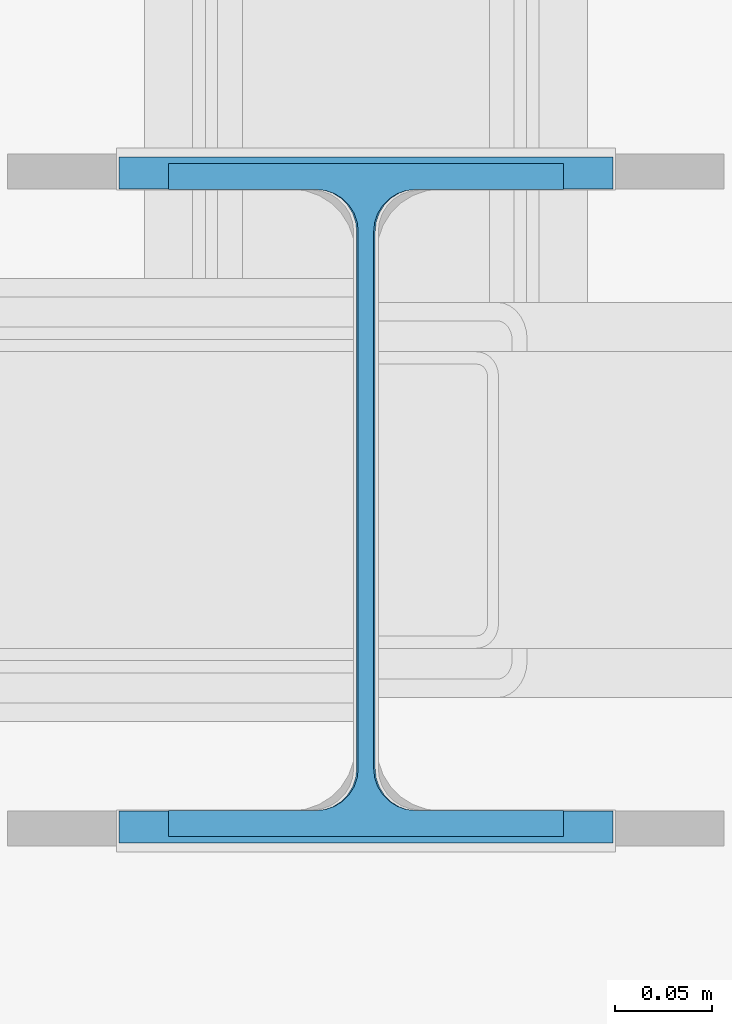
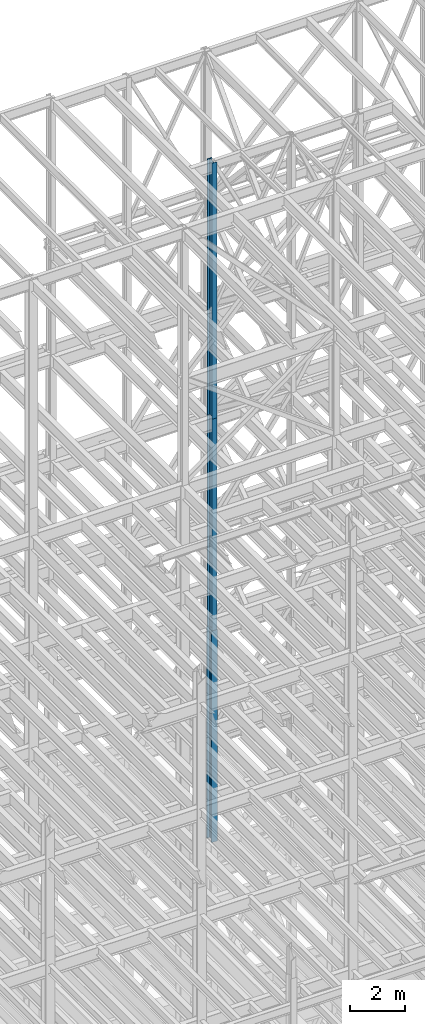
# One storey, part 40 of 150: 3 columns.
"""IFC2X3 building model written with IfcOpenShell, lengths in millimetres."""

from ifc_helpers import new_model, si_unit, frame, origin_with_axes, origin_2d_with_axis, place, context, subcontext, project, spatial, i_section, extrude, material, type_object, element, save


model = new_model("IFC2X3")

# Units and contexts
model_context = context("Model", 3, precision=1e-05, world=origin_with_axes())
body_context = subcontext(model_context, "Body", "Model", "MODEL_VIEW")
ifc_project = project(units=[si_unit("LENGTHUNIT", "METRE", prefix="MILLI"), si_unit("AREAUNIT", "SQUARE_METRE"), si_unit("VOLUMEUNIT", "CUBIC_METRE"), si_unit("MASSUNIT", "GRAM", prefix="KILO"), si_unit("TIMEUNIT", "SECOND"), si_unit("PLANEANGLEUNIT", "RADIAN"), si_unit("SOLIDANGLEUNIT", "STERADIAN"), si_unit("THERMODYNAMICTEMPERATUREUNIT", "DEGREE_CELSIUS"), si_unit("LUMINOUSINTENSITYUNIT", "LUMEN")], contexts=[model_context])

# Site, building, storey
site_placement = place(None, origin_with_axes())
site = spatial("IfcSite", under=ifc_project, at=site_placement, CompositionType="ELEMENT")
building_placement = place(site_placement, origin_with_axes())
building = spatial("IfcBuilding", under=site, at=building_placement, Name="Undefined", CompositionType="ELEMENT")
storey_placement = place(building_placement, origin_with_axes())
storey = spatial("IfcBuildingStorey", under=building, at=storey_placement, Name="Undefined", CompositionType="ELEMENT", Elevation=0.0)

# Columns
ifc_material = material(Name="STEEL/A992")
column_type_1 = type_object("IfcColumnType", Name="W14X43", PredefinedType="NOTDEFINED")
column_1_placement = place(storey_placement, frame((53238.4, 25628.6, 54483.0), z_axis=(0.0, 0.0, 1.0), x_axis=(1.0, 0.0, 0.0)))
element("IfcColumn", 1, at=column_1_placement, inside=storey, type_object=column_type_1, material=ifc_material, Name="COLUMN", ObjectType="W14X43", context=body_context, shape_type="SweptSolid", body=[
    extrude(i_section(OverallWidth=203.2, OverallDepth=346.075, WebThickness=7.9375, FlangeThickness=13.462, FilletRadius=21.4629, at=origin_2d_with_axis()), frame((0.0, 0.0, 11430.0), z_axis=(0.0, 0.0, -1.0), x_axis=(-1.0, 0.0, 0.0)), (0.0, 0.0, 1.0), 11430.0),
])
column_2_placement = place(storey_placement, frame((53238.4, 25628.6, 45034.2), z_axis=(0.0, 0.0, 1.0), x_axis=(1.0, 0.0, 0.0)))
element("IfcColumn", 2, at=column_2_placement, inside=storey, type_object=column_type_1, material=ifc_material, Name="COLUMN", ObjectType="W14X43", context=body_context, shape_type="SweptSolid", body=[
    extrude(i_section(OverallWidth=203.2, OverallDepth=346.075, WebThickness=7.9375, FlangeThickness=13.462, FilletRadius=21.4629, at=origin_2d_with_axis()), frame((0.0, 0.0, 9448.8), z_axis=(0.0, 0.0, -1.0), x_axis=(-1.0, 0.0, 0.0)), (0.0, 0.0, 1.0), 9448.8),
])
column_type_2 = type_object("IfcColumnType", Name="W14X61", PredefinedType="NOTDEFINED")
column_3_placement = place(storey_placement, frame((53238.4, 25628.6, 35585.4), z_axis=(0.0, 0.0, 1.0), x_axis=(1.0, 0.0, 0.0)))
element("IfcColumn", 3, at=column_3_placement, inside=storey, type_object=column_type_2, material=ifc_material, Name="COLUMN", ObjectType="W14X61", context=body_context, shape_type="SweptSolid", body=[
    extrude(i_section(OverallWidth=254.0, OverallDepth=352.425, WebThickness=9.5249, FlangeThickness=16.383, FilletRadius=21.717, at=origin_2d_with_axis()), frame((0.0, 0.0, 9448.8), z_axis=(0.0, 0.0, -1.0), x_axis=(-1.0, 0.0, 0.0)), (0.0, 0.0, 1.0), 9448.8),
])

save(model, "model.ifc")
